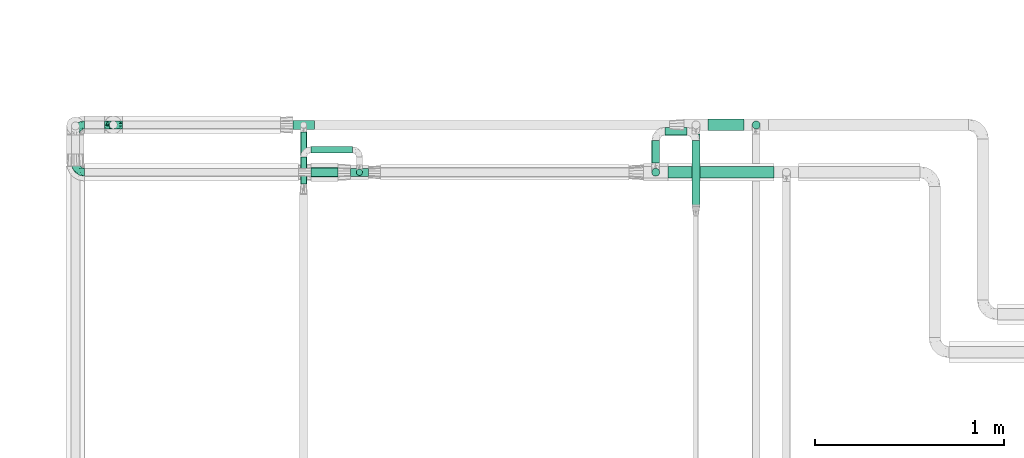
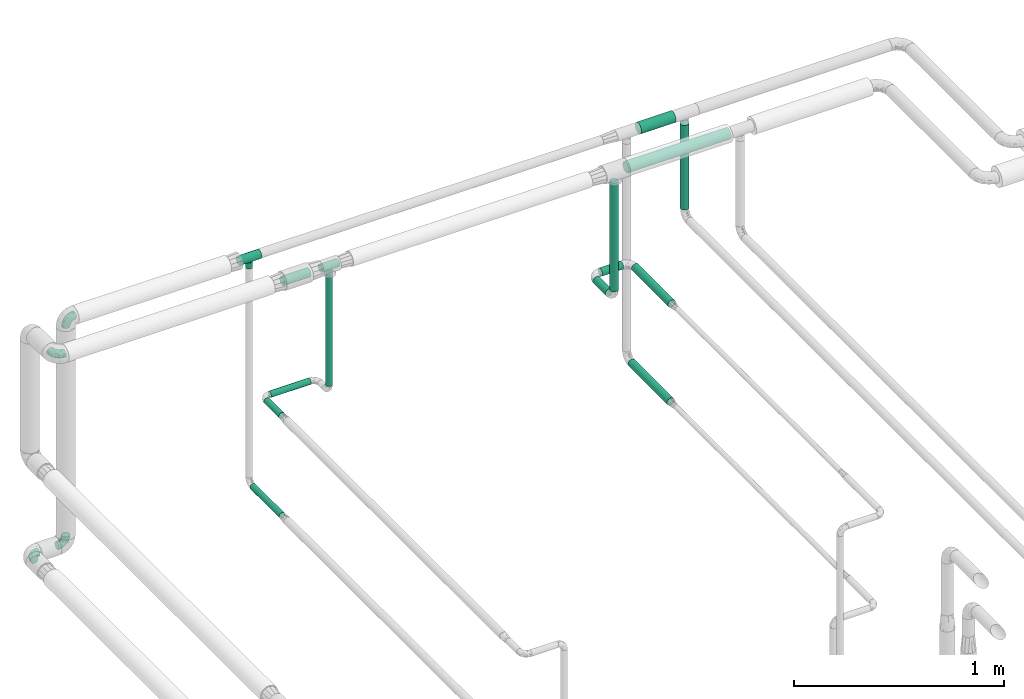
# One storey, part 580 of 827: 13 flow segments, 6 flow fittings.
"""IFC2X3 building model written with IfcOpenShell, lengths in millimetres."""

from ifc_helpers import new_model, entity, si_unit, converted_unit, derived_unit, direction, frame, origin, origin_2d_with_axis, place, context, subcontext, project, spatial, circle, extrude, faceted_brep, source, transform, mapped, material, type_object, type_shapes, element, save


model = new_model("IFC2X3")

# Units and contexts
model_context = context("Model", 3, precision=0.01, world=origin(), true_north=direction((6.12303176911189e-17, 1.0)))
body_context = subcontext(model_context, "Body", "Model", "MODEL_VIEW")
ifc_project = project(units=[si_unit("LENGTHUNIT", "METRE", prefix="MILLI"), si_unit("AREAUNIT", "SQUARE_METRE"), si_unit("VOLUMEUNIT", "CUBIC_METRE"), converted_unit("PLANEANGLEUNIT", "DEGREE", entity("IfcRatioMeasure", 0.0174532925199433), si_unit("PLANEANGLEUNIT", "RADIAN"), dimensions=[0, 0, 0, 0, 0, 0, 0]), si_unit("MASSUNIT", "GRAM", prefix="KILO"), derived_unit("MASSDENSITYUNIT", [(si_unit("MASSUNIT", "GRAM", prefix="KILO"), 1), (si_unit("LENGTHUNIT", "METRE"), -3)]), derived_unit("MOMENTOFINERTIAUNIT", [(si_unit("LENGTHUNIT", "METRE"), 4)]), si_unit("TIMEUNIT", "SECOND"), si_unit("FREQUENCYUNIT", "HERTZ"), si_unit("THERMODYNAMICTEMPERATUREUNIT", "DEGREE_CELSIUS"), derived_unit("THERMALTRANSMITTANCEUNIT", [(si_unit("MASSUNIT", "GRAM", prefix="KILO"), 1), (si_unit("THERMODYNAMICTEMPERATUREUNIT", "KELVIN"), -1), (si_unit("TIMEUNIT", "SECOND"), -3)]), derived_unit("VOLUMETRICFLOWRATEUNIT", [(si_unit("LENGTHUNIT", "METRE"), 3), (si_unit("TIMEUNIT", "SECOND"), -1)]), derived_unit("MASSFLOWRATEUNIT", [(si_unit("MASSUNIT", "GRAM", prefix="KILO"), 1), (si_unit("TIMEUNIT", "SECOND"), -1)]), derived_unit("ROTATIONALFREQUENCYUNIT", [(si_unit("TIMEUNIT", "SECOND"), -1)]), si_unit("ELECTRICCURRENTUNIT", "AMPERE"), si_unit("ELECTRICVOLTAGEUNIT", "VOLT"), si_unit("POWERUNIT", "WATT"), si_unit("FORCEUNIT", "NEWTON", prefix="KILO"), si_unit("ILLUMINANCEUNIT", "LUX"), si_unit("LUMINOUSFLUXUNIT", "LUMEN"), si_unit("LUMINOUSINTENSITYUNIT", "CANDELA"), derived_unit("USERDEFINED", [(si_unit("MASSUNIT", "GRAM", prefix="KILO"), -1), (si_unit("LENGTHUNIT", "METRE"), -2), (si_unit("TIMEUNIT", "SECOND"), 3), (si_unit("LUMINOUSFLUXUNIT", "LUMEN"), 1)]), derived_unit("LINEARVELOCITYUNIT", [(si_unit("LENGTHUNIT", "METRE"), 1), (si_unit("TIMEUNIT", "SECOND"), -1)]), si_unit("PRESSUREUNIT", "PASCAL"), derived_unit("USERDEFINED", [(si_unit("LENGTHUNIT", "METRE"), -2), (si_unit("MASSUNIT", "GRAM", prefix="KILO"), 1), (si_unit("TIMEUNIT", "SECOND"), -2)]), derived_unit("LINEARFORCEUNIT", [(si_unit("MASSUNIT", "GRAM", prefix="KILO"), 1), (si_unit("LENGTHUNIT", "METRE"), 1), (si_unit("TIMEUNIT", "SECOND"), -2), (si_unit("LENGTHUNIT", "METRE"), -1)]), derived_unit("PLANARFORCEUNIT", [(si_unit("MASSUNIT", "GRAM", prefix="KILO"), 1), (si_unit("LENGTHUNIT", "METRE"), 1), (si_unit("TIMEUNIT", "SECOND"), -2), (si_unit("LENGTHUNIT", "METRE"), -2)])], contexts=[model_context])

# Site, building, storey
site_placement = place(None, origin())
site = spatial("IfcSite", under=ifc_project, at=site_placement, CompositionType="ELEMENT")
building_placement = place(site_placement, origin())
building = spatial("IfcBuilding", under=site, at=building_placement, CompositionType="ELEMENT")
storey_placement = place(building_placement, frame((0.0, 0.0, 28200.0)))
storey = spatial("IfcBuildingStorey", under=building, at=storey_placement, Name="08", CompositionType="ELEMENT", Elevation=28200.0)

# Flow segments
pipe_segment_type = type_object("IfcPipeSegmentType", PredefinedType="NOTDEFINED")
flow_segment_1_placement = place(storey_placement, frame((15048.15, 18810.97, 2242.71)))
element("IfcFlowSegment", 1, at=flow_segment_1_placement, inside=storey, type_object=pipe_segment_type, context=body_context, shape_type="SweptSolid", body=[
    extrude(circle(Radius=21.15, at=origin_2d_with_axis()), frame((22.75, 0.0, 22.75), z_axis=(0.0, 1.0, 0.0), x_axis=(1.0, 0.0, 0.0)), (0.0, 0.0, 1.0), 120.142381818539),
])
flow_segment_2_placement = place(storey_placement, frame((15118.9, 18956.37, 2242.71)))
element("IfcFlowSegment", 2, at=flow_segment_2_placement, inside=storey, type_object=pipe_segment_type, context=body_context, shape_type="SweptSolid", body=[
    extrude(circle(Radius=21.15, at=origin_2d_with_axis()), frame((0.0, 22.75, 22.75), z_axis=(1.0, 0.0, 0.0), x_axis=(0.0, -1.0, 0.0)), (0.0, 0.0, 1.0), 116.614491839044),
])
flow_segment_3_placement = place(storey_placement, frame((15260.77, 18582.97, 2242.71)))
element("IfcFlowSegment", 3, at=flow_segment_3_placement, inside=storey, type_object=pipe_segment_type, context=body_context, shape_type="SweptSolid", body=[
    extrude(circle(Radius=21.15, at=origin_2d_with_axis()), frame((22.75, 0.0, 22.75), z_axis=(0.0, 1.0, 0.0), x_axis=(-1.0, 0.0, 0.0)), (0.0, 0.0, 1.0), 348.142381818546),
])
flow_segment_4_placement = place(storey_placement, frame((13487.6, 18744.63, 2308.25)))
element("IfcFlowSegment", 4, at=flow_segment_4_placement, inside=storey, type_object=pipe_segment_type, context=body_context, shape_type="SweptSolid", body=[
    extrude(circle(Radius=16.75, at=origin_2d_with_axis()), frame((18.35, 18.35, 0.0)), (0.0, 0.0, 1.0), 643.753648623894),
])
flow_segment_5_placement = place(storey_placement, frame((13248.89, 18737.38, 2974.4)))
element("IfcFlowSegment", 5, at=flow_segment_5_placement, inside=storey, type_object=pipe_segment_type, context=body_context, shape_type="SweptSolid", body=[
    extrude(circle(Radius=24.0, at=origin_2d_with_axis()), frame((0.0, 25.6, 25.6), z_axis=(1.0, 0.0, 0.0), x_axis=(0.0, 1.0, 0.0)), (0.0, 0.0, 1.0), 145.055644500956),
])
flow_segment_6_placement = place(storey_placement, frame((13248.97, 18863.38, 2251.9)))
element("IfcFlowSegment", 6, at=flow_segment_6_placement, inside=storey, type_object=pipe_segment_type, context=body_context, shape_type="SweptSolid", body=[
    extrude(circle(Radius=16.75, at=origin_2d_with_axis()), frame((0.0, 18.35, 18.35), z_axis=(1.0, 0.0, 0.0), x_axis=(0.0, 1.0, 0.0)), (0.0, 0.0, 1.0), 218.981935169846),
])
flow_segment_7_placement = place(storey_placement, frame((13192.62, 18700.88, 2251.9)))
element("IfcFlowSegment", 7, at=flow_segment_7_placement, inside=storey, type_object=pipe_segment_type, context=body_context, shape_type="SweptSolid", body=[
    extrude(circle(Radius=16.75, at=origin_2d_with_axis()), frame((18.35, 0.0, 18.35), z_axis=(0.0, 1.0, 0.0), x_axis=(-1.0, 0.0, 0.0)), (0.0, 0.0, 1.0), 142.847515151865),
])
flow_segment_8_placement = place(storey_placement, frame((13192.62, 18697.75, 1674.32)))
element("IfcFlowSegment", 8, at=flow_segment_8_placement, inside=storey, type_object=pipe_segment_type, context=body_context, shape_type="SweptSolid", body=[
    extrude(circle(Radius=16.75, at=origin_2d_with_axis()), frame((18.35, 0.0, 18.35), z_axis=(0.0, 1.0, 0.0), x_axis=(-1.0, 0.0, 0.0)), (0.0, 0.0, 1.0), 277.053558251562),
])
flow_segment_9_placement = place(storey_placement, frame((15260.77, 18593.49, 1667.96)))
element("IfcFlowSegment", 9, at=flow_segment_9_placement, inside=storey, type_object=pipe_segment_type, context=body_context, shape_type="SweptSolid", body=[
    extrude(circle(Radius=21.15, at=origin_2d_with_axis()), frame((22.75, 0.0, 22.75), z_axis=(0.0, 1.0, 0.0), x_axis=(-1.0, 0.0, 0.0)), (0.0, 0.0, 1.0), 371.973361835637),
])
flow_segment_10_placement = place(storey_placement, frame((15048.15, 18740.23, 2313.46)))
element("IfcFlowSegment", 10, at=flow_segment_10_placement, inside=storey, type_object=pipe_segment_type, context=body_context, shape_type="SweptSolid", body=[
    extrude(circle(Radius=21.15, at=origin_2d_with_axis()), frame((22.75, 22.75, 0.0)), (0.0, 0.0, 1.0), 629.542626520971),
])
flow_segment_11_placement = place(storey_placement, frame((15578.81, 18990.05, 2450.06)))
element("IfcFlowSegment", 11, at=flow_segment_11_placement, inside=storey, type_object=pipe_segment_type, context=body_context, shape_type="SweptSolid", body=[
    extrude(circle(Radius=21.15, at=origin_2d_with_axis()), frame((22.75, 22.75, 0.0)), (0.0, 0.0, 1.0), 492.000000000014),
])
flow_segment_12_placement = place(storey_placement, frame((15347.51, 18981.87, 2968.4)))
element("IfcFlowSegment", 12, at=flow_segment_12_placement, inside=storey, type_object=pipe_segment_type, context=body_context, shape_type="SweptSolid", body=[
    extrude(circle(Radius=30.0, at=origin_2d_with_axis()), frame((0.0, 31.6, 31.6), z_axis=(1.0, 0.0, 0.0), x_axis=(0.0, -1.0, 0.0)), (0.0, 0.0, 1.0), 190.042750716787),
])
flow_segment_13_placement = place(storey_placement, frame((15134.9, 18731.38, 2968.4)))
element("IfcFlowSegment", 13, at=flow_segment_13_placement, inside=storey, type_object=pipe_segment_type, context=body_context, shape_type="SweptSolid", body=[
    extrude(circle(Radius=30.0, at=origin_2d_with_axis()), frame((0.0, 31.6, 31.6), z_axis=(1.0, 0.0, 0.0), x_axis=(0.0, -1.0, 0.0)), (0.0, 0.0, 1.0), 562.048283667767),
])

# Flow fittings
ifc_material = material()
pipe_fitting_type_1 = type_object("IfcPipeFittingType", Name="ADSK_1", PredefinedType="NOTDEFINED", material=ifc_material)
shared_shape_1 = source(origin(), body_context, "Body", "Brep", [
    faceted_brep([(-48.0, 10.6, -18.36), (-48.0, 5.49, -20.48), (-48.0, 0.0, -21.2), (-48.0, -5.49, -20.48), (-48.0, -10.6, -18.36), (-48.0, -14.99, -14.99), (-48.0, -18.36, -10.6), (-48.0, -20.48, -5.49), (-48.0, -21.2, 0.0), (-48.0, -20.48, 5.49), (-48.0, -18.36, 10.6), (-48.0, -14.99, 14.99), (-48.0, -10.6, 18.36), (-48.0, -5.49, 20.48), (-48.0, 0.0, 21.2), (-48.0, 5.49, 20.48), (-48.0, 10.6, 18.36), (-48.0, 14.99, 14.99), (-48.0, 18.36, 10.6), (-48.0, 20.48, 5.49), (-48.0, 21.2, 0.0), (-48.0, 20.48, -5.49), (-48.0, 18.36, -10.6), (-48.0, 14.99, -14.99), (0.0, 48.0, -21.2), (-5.49, 48.0, -20.48), (-10.6, 48.0, -18.36), (-14.99, 48.0, -14.99), (-18.36, 48.0, -10.6), (-20.48, 48.0, -5.49), (-21.2, 48.0, 0.0), (-20.48, 48.0, 5.49), (-18.36, 48.0, 10.6), (-14.99, 48.0, 14.99), (-10.6, 48.0, 18.36), (-5.49, 48.0, 20.48), (0.0, 48.0, 21.2), (5.49, 48.0, 20.48), (10.6, 48.0, 18.36), (14.99, 48.0, 14.99), (18.36, 48.0, 10.6), (20.48, 48.0, 5.49), (21.2, 48.0, 0.0), (20.48, 48.0, -5.49), (18.36, 48.0, -10.6), (14.99, 48.0, -14.99), (10.6, 48.0, -18.36), (5.49, 48.0, -20.48), (-35.25, -16.22, 12.01), (-34.76, -18.57, 0.0), (-20.87, -12.37, 10.9), (-31.49, -11.78, 15.9), (-37.0, -2.58, 20.86), (-33.89, 3.62, 21.15), (-31.81, -18.14, 6.76), (-5.78, 5.78, 17.67), (-19.42, -4.1, 17.86), (-9.6, -3.39, 13.73), (-35.44, -7.73, 19.13), (11.78, 31.49, 15.9), (-5.93, -5.46, 6.95), (-18.45, -13.78, 5.46), (-10.29, -8.43, 0.0), (-24.6, 0.55, 20.62), (-37.28, 17.94, 13.81), (-33.38, 22.85, 9.59), (-41.46, 20.06, 8.75), (-29.51, 20.45, 15.16), (-15.04, 10.79, 21.13), (-7.08, 16.98, 20.93), (-8.39, 23.51, 21.15), (-40.86, 13.03, 17.26), (-8.05, 41.26, 19.83), (-3.21, 35.97, 21.14), (8.53, 19.66, 14.74), (4.1, 19.42, 17.86), (-37.72, 22.66, 4.78), (-37.07, 8.58, 19.98), (-13.0, 5.43, 19.97), (-3.78, 13.93, 19.7), (3.02, 8.69, 13.43), (-2.27, -0.05, 10.65), (6.22, 6.99, 7.09), (-22.25, 34.6, 9.45), (18.14, 31.81, 6.76), (16.22, 35.25, 12.01), (12.37, 20.87, 10.9), (7.73, 35.44, 19.13), (-21.52, -15.93, 0.0), (2.58, 37.0, 20.86), (18.57, 34.76, 0.0), (13.78, 18.45, 5.46), (15.93, 21.52, 0.0), (-20.03, -8.54, 14.9), (-28.6, 28.6, 5.16), (-24.79, 34.6, 0.0), (-34.6, 24.79, 0.0), (-22.81, 37.41, 4.68), (-23.36, 26.33, 14.79), (-13.68, 37.05, 17.49), (-17.72, 38.12, 13.73), (-26.25, 27.3, 11.24), (-9.71, 32.34, 20.14), (-17.26, 25.6, 18.71), (-26.33, 9.99, 20.77), (-24.06, 6.05, 21.2), (-25.02, 15.46, 19.56), (-24.3, 20.72, 17.57), (-31.95, 15.23, 17.8), (-13.53, 24.7, 20.21), (-17.6, 17.6, 20.6), (-0.55, 24.6, 20.62), (-11.41, -7.48, 10.43), (0.93, -0.93, 0.0), (8.43, 10.29, 0.0), (-11.41, -7.48, -10.43), (-20.1, -8.84, -14.66), (-9.6, -3.39, -13.73), (7.73, 35.44, -19.13), (4.1, 19.42, -17.86), (-0.55, 24.6, -20.62), (-38.12, 17.72, -13.73), (-37.05, 13.68, -17.49), (-32.34, 9.71, -20.14), (-41.26, 8.05, -19.83), (-37.41, 22.81, -4.68), (-23.51, 8.39, -21.15), (-35.97, 3.21, -21.14), (-28.6, 28.6, -5.16), (-31.81, -18.14, -6.76), (-18.45, -13.78, -5.46), (-25.6, 17.26, -18.71), (-19.42, -4.1, -17.86), (-17.94, 37.28, -13.81), (-22.85, 33.38, -9.59), (-20.06, 41.46, -8.75), (-31.49, -11.78, -15.9), (-35.25, -16.22, -12.01), (8.53, 19.66, -14.74), (11.78, 31.49, -15.9), (-9.99, 26.33, -20.77), (-6.05, 24.06, -21.2), (-10.79, 15.04, -21.13), (-37.0, -2.58, -20.86), (-16.98, 7.08, -20.93), (-5.43, 13.0, -19.97), (-13.93, 3.78, -19.7), (-20.87, -12.37, -10.9), (-26.33, 23.36, -14.79), (-22.66, 37.72, -4.78), (13.78, 18.45, -5.46), (18.14, 31.81, -6.76), (-15.46, 25.02, -19.56), (-20.72, 24.3, -17.57), (16.22, 35.25, -12.01), (-13.03, 40.86, -17.26), (-8.58, 37.07, -19.98), (2.58, 37.0, -20.86), (-3.62, 33.89, -21.15), (-34.6, 22.25, -9.45), (6.22, 6.99, -7.09), (-20.45, 29.51, -15.16), (-35.44, -7.73, -19.13), (12.37, 20.87, -10.9), (-27.3, 26.25, -11.24), (-15.23, 31.95, -17.8), (-24.7, 13.53, -20.21), (-24.6, 0.55, -20.62), (-5.78, 5.78, -17.67), (-17.6, 17.6, -20.6), (3.02, 8.69, -13.43), (-5.93, -5.46, -6.95), (-2.27, -0.05, -10.65)], [[[0, 1, 2, 3, 4, 5, 6, 7, 8, 9, 10, 11, 12, 13, 14, 15, 16, 17, 18, 19, 20, 21, 22, 23]], [[24, 25, 26, 27, 28, 29, 30, 31, 32, 33, 34, 35, 36, 37, 38, 39, 40, 41, 42, 43, 44, 45, 46, 47]], [[10, 48, 11]], [[9, 8, 49]], [[48, 50, 51]], [[14, 52, 53]], [[10, 54, 48]], [[9, 54, 10]], [[55, 56, 57]], [[51, 12, 11]], [[51, 58, 12]], [[59, 39, 38]], [[60, 61, 62]], [[58, 56, 63]], [[64, 65, 66]], [[67, 65, 64]], [[68, 69, 70]], [[16, 71, 17]], [[13, 52, 14]], [[35, 72, 73]], [[14, 53, 15]], [[17, 64, 18]], [[74, 59, 75]], [[20, 19, 76]], [[66, 19, 18]], [[77, 15, 53]], [[15, 77, 16]], [[69, 78, 79]], [[80, 81, 82]], [[32, 31, 83]], [[84, 85, 86]], [[59, 87, 75]], [[61, 54, 88]], [[36, 89, 37]], [[84, 41, 40]], [[36, 35, 73]], [[90, 41, 84]], [[40, 39, 85]], [[12, 58, 13]], [[85, 84, 40]], [[91, 84, 86]], [[84, 92, 90]], [[87, 38, 37]], [[93, 56, 51]], [[65, 94, 76]], [[94, 95, 96]], [[84, 91, 92]], [[95, 97, 30]], [[98, 99, 100]], [[76, 94, 96]], [[101, 98, 83]], [[100, 99, 33]], [[102, 70, 73]], [[103, 102, 99]], [[94, 97, 95]], [[72, 99, 102]], [[72, 35, 34]], [[34, 33, 99]], [[9, 49, 54]], [[87, 59, 38]], [[104, 105, 68]], [[106, 103, 107]], [[106, 77, 104]], [[71, 64, 17]], [[108, 107, 67]], [[33, 32, 100]], [[109, 103, 110]], [[102, 109, 70]], [[89, 73, 111]], [[50, 48, 54]], [[51, 11, 48]], [[56, 58, 51]], [[88, 54, 49]], [[52, 58, 63]], [[50, 112, 93]], [[56, 55, 78]], [[39, 59, 85]], [[86, 85, 59]], [[89, 87, 37]], [[42, 41, 90]], [[111, 79, 75]], [[111, 75, 87]], [[75, 55, 80]], [[104, 77, 53]], [[71, 77, 108]], [[32, 83, 100]], [[98, 100, 83]], [[99, 98, 103]], [[106, 107, 108]], [[68, 70, 110]], [[111, 73, 70]], [[68, 110, 104]], [[68, 63, 78]], [[57, 93, 112]], [[80, 55, 57]], [[61, 50, 54]], [[80, 82, 86]], [[81, 57, 112]], [[74, 86, 59]], [[60, 113, 82]], [[82, 114, 91]], [[101, 94, 65]], [[97, 94, 83]], [[73, 89, 36]], [[87, 89, 111]], [[58, 52, 13]], [[53, 52, 63]], [[104, 53, 105]], [[106, 104, 110]], [[20, 76, 96]], [[76, 19, 66]], [[103, 106, 110]], [[77, 106, 108]], [[103, 98, 107]], [[67, 107, 98]], [[67, 98, 101]], [[108, 67, 64]], [[53, 63, 105]], [[63, 68, 105]], [[83, 31, 97]], [[30, 97, 31]], [[62, 113, 60]], [[112, 61, 60]], [[61, 88, 62]], [[86, 82, 91]], [[56, 78, 63]], [[114, 82, 113]], [[114, 92, 91]], [[79, 78, 55]], [[75, 79, 55]], [[69, 79, 111]], [[70, 69, 111]], [[78, 69, 68]], [[77, 71, 16]], [[64, 71, 108]], [[64, 66, 18]], [[76, 66, 65]], [[99, 72, 34]], [[73, 72, 102]], [[94, 101, 83]], [[67, 101, 65]], [[75, 80, 74]], [[80, 86, 74]], [[70, 109, 110]], [[102, 103, 109]], [[50, 93, 51]], [[57, 56, 93]], [[61, 112, 50]], [[81, 112, 60]], [[82, 81, 60]], [[80, 57, 81]], [[115, 116, 117]], [[118, 119, 120]], [[121, 122, 23]], [[123, 124, 122]], [[96, 125, 20]], [[123, 126, 127]], [[128, 96, 95]], [[129, 130, 88]], [[123, 122, 131]], [[116, 132, 117]], [[133, 134, 135]], [[0, 124, 1]], [[5, 136, 137]], [[138, 119, 139]], [[129, 88, 49]], [[140, 141, 142]], [[6, 5, 137]], [[46, 118, 47]], [[143, 3, 2]], [[144, 145, 146]], [[6, 129, 7]], [[129, 137, 147]], [[127, 2, 1]], [[148, 122, 121]], [[128, 125, 96]], [[134, 128, 149]], [[95, 149, 128]], [[150, 151, 92]], [[30, 29, 149]], [[152, 131, 153]], [[27, 133, 28]], [[154, 45, 44]], [[136, 5, 4]], [[27, 26, 155]], [[156, 26, 25]], [[24, 157, 158]], [[24, 47, 157]], [[22, 21, 159]], [[160, 150, 114]], [[134, 133, 161]], [[142, 144, 126]], [[46, 139, 118]], [[162, 136, 4]], [[156, 25, 158]], [[1, 124, 127]], [[115, 147, 116]], [[45, 154, 139]], [[139, 46, 45]], [[154, 163, 139]], [[162, 4, 3]], [[42, 90, 43]], [[130, 129, 147]], [[49, 7, 129]], [[43, 151, 44]], [[0, 23, 122]], [[24, 158, 25]], [[136, 162, 132]], [[135, 29, 28]], [[43, 90, 151]], [[164, 148, 159]], [[152, 156, 140]], [[155, 133, 27]], [[165, 153, 161]], [[23, 22, 121]], [[123, 131, 166]], [[123, 166, 126]], [[143, 127, 167]], [[147, 137, 136]], [[8, 7, 49]], [[129, 6, 137]], [[143, 162, 3]], [[167, 146, 132]], [[167, 132, 162]], [[132, 168, 117]], [[44, 151, 154]], [[92, 151, 90]], [[163, 154, 151]], [[119, 118, 139]], [[157, 118, 120]], [[138, 139, 163]], [[119, 168, 145]], [[140, 156, 158]], [[155, 156, 165]], [[22, 159, 121]], [[148, 121, 159]], [[122, 148, 131]], [[152, 153, 165]], [[142, 126, 169]], [[167, 127, 126]], [[142, 169, 140]], [[142, 120, 145]], [[168, 170, 117]], [[160, 171, 172]], [[115, 172, 171]], [[171, 62, 130]], [[119, 170, 168]], [[170, 163, 160]], [[150, 163, 151]], [[113, 171, 160]], [[164, 128, 134]], [[125, 128, 159]], [[127, 143, 2]], [[162, 143, 167]], [[118, 157, 47]], [[158, 157, 120]], [[140, 158, 141]], [[152, 140, 169]], [[30, 149, 95]], [[149, 29, 135]], [[131, 152, 169]], [[156, 152, 165]], [[131, 148, 153]], [[161, 153, 148]], [[161, 148, 164]], [[165, 161, 133]], [[158, 120, 141]], [[120, 142, 141]], [[159, 21, 125]], [[20, 125, 21]], [[115, 130, 147]], [[114, 113, 160]], [[62, 171, 113]], [[62, 88, 130]], [[160, 163, 150]], [[150, 92, 114]], [[119, 145, 120]], [[146, 145, 168]], [[132, 146, 168]], [[144, 146, 167]], [[126, 144, 167]], [[145, 144, 142]], [[156, 155, 26]], [[133, 155, 165]], [[133, 135, 28]], [[149, 135, 134]], [[122, 124, 0]], [[127, 124, 123]], [[128, 164, 159]], [[161, 164, 134]], [[163, 170, 138]], [[170, 119, 138]], [[131, 169, 166]], [[126, 166, 169]], [[147, 136, 116]], [[132, 116, 136]], [[172, 115, 117]], [[130, 115, 171]], [[117, 170, 172]], [[160, 172, 170]]]),
])
type_shapes(pipe_fitting_type_1, [shared_shape_1])
for number, where, z_axis, x_axis, name in (
    (14, (12005.46, 18762.97, 3000.0), (0.0, 0.0, 1.0), (0.0, -1.0, 0.0), "ADSK_1"),
    (15, (12205.95, 19013.47, 3000.0), (0.0, -1.0, 0.0), (-1.0, 0.0, 0.0), "ADSK_1"),
    (16, (12205.95, 19013.47, 1694.27), (0.0, 1.0, 0.0), (0.0, 0.0, -1.0), "ADSK_1"),
    (17, (12005.95, 19013.47, 1694.27), (0.0, 0.0, 1.0), (-1.0, 0.0, 0.0), "ADSK_1"),
):
    element("IfcFlowFitting", number, at=place(storey_placement, frame(where, z_axis=z_axis, x_axis=x_axis)), inside=storey, type_object=pipe_fitting_type_1, material=ifc_material, Name=name, ObjectType="ADSK_1", context=body_context, shape_type="MappedRepresentation", body=[
        mapped(shared_shape_1, transform((0.0, 0.0, 0.0), scale=1.0)),
    ])
pipe_fitting_type_2 = type_object("IfcPipeFittingType", Name="ADSK_1", PredefinedType="NOTDEFINED", material=ifc_material)
shared_shape_2 = source(origin(), body_context, "Body", "Brep", [
    faceted_brep([(-48.0, 10.6, -18.36), (-48.0, 5.49, -20.48), (-48.0, 0.0, -21.2), (-48.0, -5.49, -20.48), (-48.0, -10.6, -18.36), (-48.0, -14.99, -14.99), (-48.0, -18.36, -10.6), (-48.0, -20.48, -5.49), (-48.0, -21.2, 0.0), (-48.0, -20.48, 5.49), (-48.0, -18.36, 10.6), (-48.0, -14.99, 14.99), (-48.0, -10.6, 18.36), (-48.0, -5.49, 20.48), (-48.0, 0.0, 21.2), (-48.0, 5.49, 20.48), (-48.0, 10.6, 18.36), (-48.0, 14.99, 14.99), (-48.0, 18.36, 10.6), (-48.0, 20.48, 5.49), (-48.0, 21.2, 0.0), (-48.0, 20.48, -5.49), (-48.0, 18.36, -10.6), (-48.0, 14.99, -14.99), (48.0, 0.0, -21.2), (48.0, 5.49, -20.48), (48.0, 10.6, -18.36), (48.0, 14.99, -14.99), (48.0, 18.36, -10.6), (48.0, 20.48, -5.49), (48.0, 21.2, 0.0), (48.0, 20.48, 5.49), (48.0, 18.36, 10.6), (48.0, 14.99, 14.99), (48.0, 10.6, 18.36), (48.0, 5.49, 20.48), (48.0, 0.0, 21.2), (48.0, -5.49, 20.48), (48.0, -10.6, 18.36), (48.0, -14.99, 14.99), (48.0, -18.36, 10.6), (48.0, -20.48, 5.49), (48.0, -21.2, 0.0), (48.0, -20.48, -5.49), (48.0, -18.36, -10.6), (48.0, -14.99, -14.99), (48.0, -10.6, -18.36), (48.0, -5.49, -20.48), (16.85, -21.2, 0.0), (-16.85, -21.2, 0.0), (15.74, -20.33, 6.01), (16.3, -20.76, 3.01), (12.78, -18.13, 10.98), (8.5, -15.42, 14.55), (3.07, -13.23, 16.57), (-16.3, -20.76, 3.01), (-15.74, -20.33, 6.01), (-8.5, -15.42, 14.55), (-3.07, -13.23, 16.57), (-12.78, -18.13, 10.98), (0.0, -13.23, 16.57), (3.07, -13.23, -16.57), (12.78, -18.13, -10.98), (8.5, -15.42, -14.55), (15.74, -20.33, -6.01), (16.3, -20.76, -3.01), (-3.07, -13.23, -16.57), (-8.5, -15.42, -14.55), (-12.78, -18.13, -10.98), (-15.74, -20.33, -6.01), (-16.3, -20.76, -3.01), (0.0, -13.23, -16.57), (4.36, -48.0, -16.28), (8.43, -48.0, -14.59), (11.91, -48.0, -11.91), (14.59, -48.0, -8.43), (16.28, -48.0, -4.36), (16.85, -48.0, 0.0), (16.28, -48.0, 4.36), (14.59, -48.0, 8.42), (11.91, -48.0, 11.91), (8.43, -48.0, 14.59), (4.36, -48.0, 16.28), (0.0, -48.0, 16.85), (-4.36, -48.0, 16.28), (-8.42, -48.0, 14.59), (-11.91, -48.0, 11.91), (-14.59, -48.0, 8.42), (-16.28, -48.0, 4.36), (-16.85, -48.0, 0.0), (-16.28, -48.0, -4.36), (-14.59, -48.0, -8.43), (-11.91, -48.0, -11.91), (-8.42, -48.0, -14.59), (-4.36, -48.0, -16.28), (0.0, -48.0, -16.85)], [[[0, 1, 2, 3, 4, 5, 6, 7, 8, 9, 10, 11, 12, 13, 14, 15, 16, 17, 18, 19, 20, 21, 22, 23]], [[24, 25, 26, 27, 28, 29, 30, 31, 32, 33, 34, 35, 36, 37, 38, 39, 40, 41, 42, 43, 44, 45, 46, 47]], [[42, 41, 48]], [[9, 8, 49]], [[41, 50, 51, 48]], [[41, 40, 50]], [[40, 39, 52]], [[53, 52, 39]], [[54, 53, 39]], [[39, 38, 54]], [[40, 52, 50]], [[9, 49, 55, 56]], [[56, 10, 9]], [[57, 58, 11]], [[10, 59, 11]], [[59, 10, 56]], [[11, 59, 57]], [[58, 12, 11]], [[12, 58, 60, 54]], [[14, 13, 37, 36]], [[13, 12, 38, 37]], [[15, 14, 36, 35]], [[32, 31, 19, 18]], [[17, 16, 34, 33]], [[18, 17, 33, 32]], [[35, 34, 16, 15]], [[20, 19, 31, 30]], [[38, 12, 54]], [[29, 28, 22, 21]], [[28, 27, 23, 22]], [[30, 29, 21, 20]], [[24, 47, 3, 2]], [[25, 1, 0, 26]], [[2, 1, 25, 24]], [[26, 0, 23, 27]], [[4, 3, 47, 46]], [[46, 61, 4]], [[45, 62, 63]], [[62, 45, 44]], [[63, 61, 45]], [[45, 61, 46]], [[43, 42, 48]], [[7, 49, 8]], [[43, 64, 44]], [[43, 48, 65, 64]], [[44, 64, 62]], [[66, 67, 5]], [[5, 68, 6]], [[68, 5, 67]], [[66, 5, 4]], [[7, 69, 70, 49]], [[69, 7, 6]], [[69, 6, 68]], [[4, 61, 71, 66]], [[72, 73, 74, 75, 76, 77, 78, 79, 80, 81, 82, 83, 84, 85, 86, 87, 88, 89, 90, 91, 92, 93, 94, 95]], [[51, 77, 48]], [[57, 86, 85]], [[86, 59, 87]], [[57, 85, 84]], [[55, 49, 89]], [[89, 88, 55]], [[88, 87, 56]], [[88, 56, 55]], [[59, 56, 87]], [[86, 57, 59]], [[51, 50, 78]], [[84, 58, 57]], [[83, 54, 60, 58]], [[53, 82, 81]], [[80, 53, 81]], [[50, 79, 78]], [[80, 79, 52]], [[54, 83, 82]], [[82, 53, 54]], [[83, 58, 84]], [[53, 80, 52]], [[52, 79, 50]], [[77, 51, 78]], [[76, 65, 77]], [[95, 61, 72]], [[70, 89, 49]], [[76, 64, 65]], [[76, 75, 64]], [[74, 62, 75]], [[65, 48, 77]], [[64, 75, 62]], [[73, 72, 63]], [[63, 62, 74]], [[63, 72, 61]], [[63, 74, 73]], [[95, 66, 71, 61]], [[67, 94, 93]], [[92, 67, 93]], [[69, 91, 90]], [[92, 91, 68]], [[66, 95, 94]], [[94, 67, 66]], [[67, 92, 68]], [[68, 91, 69]], [[89, 70, 90]], [[70, 69, 90]]]),
])
type_shapes(pipe_fitting_type_2, [shared_shape_2])
flow_fitting_1_placement = place(storey_placement, frame((13505.95, 18762.97, 3000.0), z_axis=(0.0, 1.0, 0.0), x_axis=(-1.0, 0.0, 0.0)))
element("IfcFlowFitting", 18, at=flow_fitting_1_placement, inside=storey, type_object=pipe_fitting_type_2, material=ifc_material, Name="ADSK_1", ObjectType="ADSK_1", context=body_context, shape_type="MappedRepresentation", body=[
    mapped(shared_shape_2, transform((0.0, 0.0, 0.0), scale=1.0)),
])
pipe_fitting_type_3 = type_object("IfcPipeFittingType", Name="ADSK_1", PredefinedType="NOTDEFINED", material=ifc_material)
shared_shape_3 = source(origin(), body_context, "Body", "Brep", [
    faceted_brep([(-57.0, 12.07, -20.91), (-57.0, 6.25, -23.33), (-57.0, 0.0, -24.15), (-57.0, -6.25, -23.33), (-57.0, -12.08, -20.91), (-57.0, -17.08, -17.08), (-57.0, -20.91, -12.08), (-57.0, -23.33, -6.25), (-57.0, -24.15, 0.0), (-57.0, -23.33, 6.25), (-57.0, -20.91, 12.07), (-57.0, -17.08, 17.08), (-57.0, -12.08, 20.91), (-57.0, -6.25, 23.33), (-57.0, 0.0, 24.15), (-57.0, 6.25, 23.33), (-57.0, 12.07, 20.91), (-57.0, 17.08, 17.08), (-57.0, 20.91, 12.07), (-57.0, 23.33, 6.25), (-57.0, 24.15, 0.0), (-57.0, 23.33, -6.25), (-57.0, 20.91, -12.08), (-57.0, 17.08, -17.08), (57.0, 0.0, -24.15), (57.0, 6.25, -23.33), (57.0, 12.07, -20.91), (57.0, 17.08, -17.08), (57.0, 20.91, -12.08), (57.0, 23.33, -6.25), (57.0, 24.15, 0.0), (57.0, 23.33, 6.25), (57.0, 20.91, 12.07), (57.0, 17.08, 17.08), (57.0, 12.07, 20.91), (57.0, 6.25, 23.33), (57.0, 0.0, 24.15), (57.0, -6.25, 23.33), (57.0, -12.08, 20.91), (57.0, -17.08, 17.08), (57.0, -20.91, 12.07), (57.0, -23.33, 6.25), (57.0, -24.15, 0.0), (57.0, -23.33, -6.25), (57.0, -20.91, -12.08), (57.0, -17.08, -17.08), (57.0, -12.08, -20.91), (57.0, -6.25, -23.33), (15.77, -23.41, 5.93), (16.31, -23.78, 2.97), (16.85, -24.15, 0.0), (12.83, -21.54, 10.92), (8.5, -19.28, 14.55), (3.03, -17.56, 16.58), (-3.03, -17.56, 16.58), (0.0, -17.56, 16.58), (-16.85, -24.15, 0.0), (-16.31, -23.78, 2.96), (-15.77, -23.41, 5.93), (-12.84, -21.54, 10.92), (-8.5, -19.28, 14.55), (3.03, -17.56, -16.58), (8.5, -19.28, -14.55), (12.83, -21.54, -10.92), (0.0, -17.56, -16.58), (-3.03, -17.56, -16.58), (15.77, -23.41, -5.93), (16.31, -23.78, -2.97), (-8.5, -19.28, -14.55), (-12.84, -21.54, -10.92), (-15.77, -23.41, -5.93), (-16.31, -23.78, -2.96), (11.91, -57.0, -11.91), (14.59, -57.0, -8.43), (16.28, -57.0, -4.36), (16.85, -57.0, 0.0), (16.28, -57.0, 4.36), (14.59, -57.0, 8.42), (11.91, -57.0, 11.91), (8.43, -57.0, 14.59), (4.36, -57.0, 16.28), (0.0, -57.0, 16.85), (-4.36, -57.0, 16.28), (-8.42, -57.0, 14.59), (-11.91, -57.0, 11.91), (-14.59, -57.0, 8.42), (-16.28, -57.0, 4.36), (-16.85, -57.0, 0.0), (-16.28, -57.0, -4.36), (-14.59, -57.0, -8.43), (-11.91, -57.0, -11.91), (-8.42, -57.0, -14.59), (-4.36, -57.0, -16.28), (0.0, -57.0, -16.85), (4.36, -57.0, -16.28), (8.43, -57.0, -14.59)], [[[0, 1, 2, 3, 4, 5, 6, 7, 8, 9, 10, 11, 12, 13, 14, 15, 16, 17, 18, 19, 20, 21, 22, 23]], [[24, 25, 26, 27, 28, 29, 30, 31, 32, 33, 34, 35, 36, 37, 38, 39, 40, 41, 42, 43, 44, 45, 46, 47]], [[42, 41, 48]], [[42, 48, 49, 50]], [[41, 51, 48]], [[40, 39, 52]], [[52, 51, 40]], [[53, 52, 39]], [[12, 54, 55, 53]], [[40, 51, 41]], [[8, 56, 57, 58]], [[9, 8, 58]], [[58, 59, 9]], [[60, 54, 11]], [[60, 10, 59]], [[10, 60, 11]], [[59, 10, 9]], [[11, 54, 12]], [[53, 39, 38]], [[14, 13, 37, 36]], [[13, 12, 38, 37]], [[15, 14, 36, 35]], [[32, 31, 19, 18]], [[17, 16, 34, 33]], [[18, 17, 33, 32]], [[35, 34, 16, 15]], [[20, 19, 31, 30]], [[38, 12, 53]], [[29, 28, 22, 21]], [[28, 27, 23, 22]], [[30, 29, 21, 20]], [[24, 47, 3, 2]], [[1, 0, 26, 25]], [[2, 1, 25, 24]], [[27, 26, 0, 23]], [[4, 3, 47, 46]], [[46, 61, 4]], [[45, 44, 62]], [[62, 61, 45]], [[44, 63, 62]], [[4, 61, 64, 65]], [[43, 42, 66]], [[66, 63, 43]], [[42, 50, 67, 66]], [[43, 63, 44]], [[65, 68, 5]], [[6, 5, 68]], [[68, 69, 6]], [[5, 4, 65]], [[69, 70, 7]], [[70, 8, 7]], [[8, 70, 71, 56]], [[69, 7, 6]], [[61, 46, 45]], [[72, 73, 74, 75, 76, 77, 78, 79, 80, 81, 82, 83, 84, 85, 86, 87, 88, 89, 90, 91, 92, 93, 94, 95]], [[58, 86, 85]], [[60, 84, 83]], [[85, 84, 59]], [[60, 83, 82]], [[57, 87, 86]], [[56, 87, 57]], [[86, 58, 57]], [[59, 58, 85]], [[84, 60, 59]], [[49, 75, 50]], [[82, 54, 60]], [[81, 53, 55, 54]], [[52, 80, 79]], [[78, 52, 79]], [[48, 77, 76]], [[78, 77, 51]], [[53, 81, 80]], [[80, 52, 53]], [[81, 54, 82]], [[52, 78, 51]], [[51, 77, 48]], [[49, 48, 76]], [[75, 49, 76]], [[74, 67, 75]], [[71, 70, 88]], [[93, 61, 94]], [[71, 87, 56]], [[74, 66, 67]], [[66, 74, 73]], [[63, 73, 72]], [[67, 50, 75]], [[66, 73, 63]], [[95, 94, 62]], [[62, 63, 72]], [[62, 94, 61]], [[62, 72, 95]], [[93, 65, 64, 61]], [[68, 92, 91]], [[90, 68, 91]], [[70, 89, 88]], [[90, 89, 69]], [[65, 93, 92]], [[92, 68, 65]], [[68, 90, 69]], [[69, 89, 70]], [[87, 71, 88]]]),
])
type_shapes(pipe_fitting_type_3, [shared_shape_3])
flow_fitting_2_placement = place(storey_placement, frame((13210.97, 19012.8, 2999.06), z_axis=(0.0, 1.0, 0.0), x_axis=(-1.0, 0.0, 0.0)))
element("IfcFlowFitting", 19, at=flow_fitting_2_placement, inside=storey, type_object=pipe_fitting_type_3, material=ifc_material, Name="ADSK_1", ObjectType="ADSK_1", context=body_context, shape_type="MappedRepresentation", body=[
    mapped(shared_shape_3, transform((0.0, 0.0, 0.0), scale=1.0)),
])

save(model, "model.ifc")
